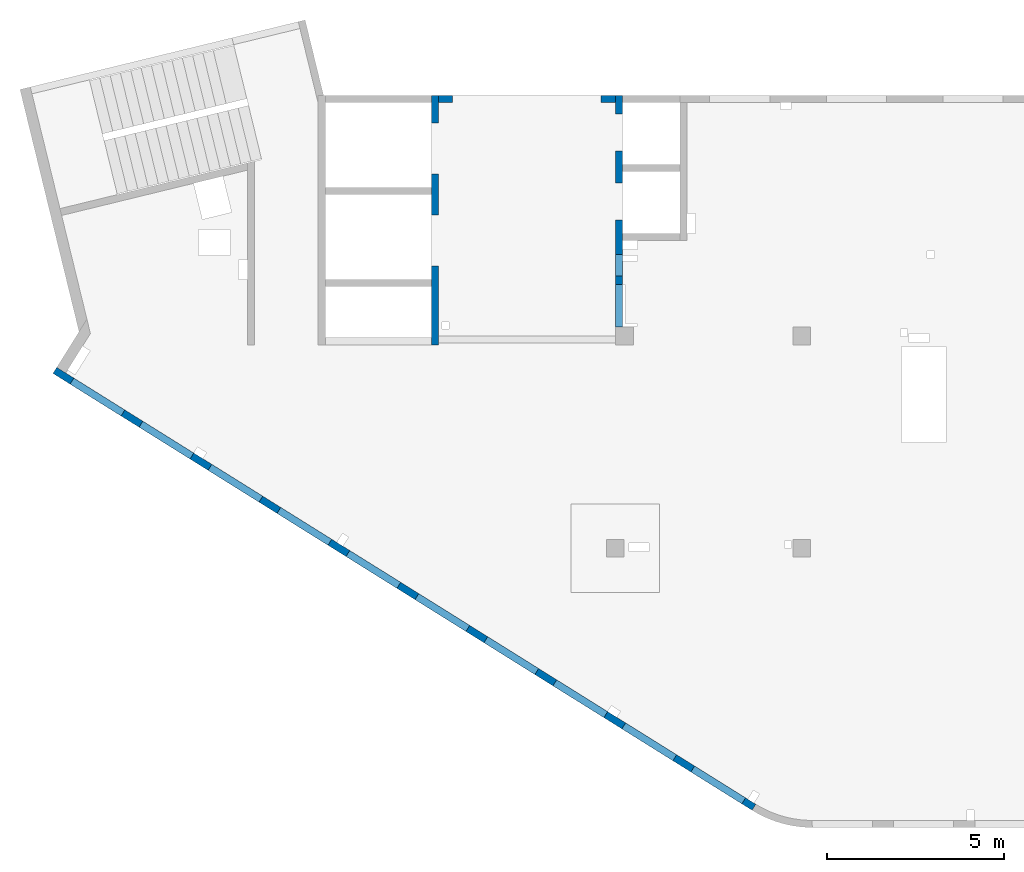
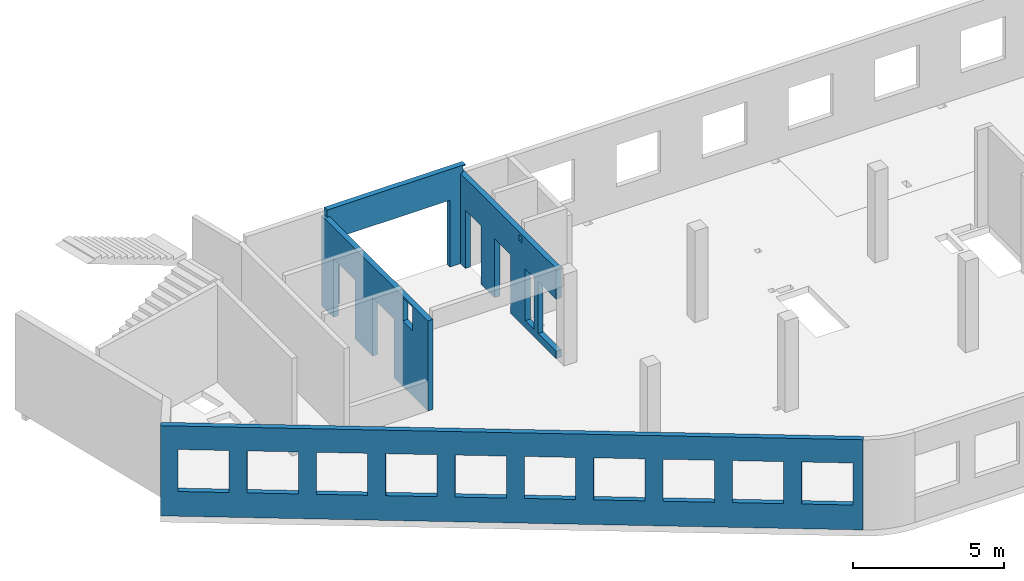
# One storey, part 4 of 6: 4 walls, 19 openings.
"""IFC4 building model written with IfcOpenShell, lengths in millimetres."""

from ifc_helpers import new_model, entity, si_unit, converted_unit, derived_unit, direction, frame, origin, place, context, subcontext, project, spatial, indexed_curve, outline, extrude, polygons, material, type_object, element, save


model = new_model("IFC4")

# Units and contexts
model_context = context("Model", 3, precision=0.01, world=origin(), true_north=direction((6.12303176911189e-17, 1.0)))
plan_context = context("Plan", 3, precision=0.01, world=origin(), true_north=direction((6.12303176911189e-17, 1.0)))
body_context = subcontext(model_context, "Body", "Model", "MODEL_VIEW")
ifc_project = project(units=[si_unit("LENGTHUNIT", "METRE", prefix="MILLI"), si_unit("AREAUNIT", "SQUARE_METRE"), si_unit("VOLUMEUNIT", "CUBIC_METRE"), converted_unit("PLANEANGLEUNIT", "DEGREE", entity("IfcRatioMeasure", 0.0174532925199433), si_unit("PLANEANGLEUNIT", "RADIAN"), dimensions=[0, 0, 0, 0, 0, 0, 0]), si_unit("MASSUNIT", "GRAM", prefix="KILO"), derived_unit("MASSDENSITYUNIT", [(si_unit("MASSUNIT", "GRAM", prefix="KILO"), 1), (si_unit("LENGTHUNIT", "METRE"), -3)]), derived_unit("MOMENTOFINERTIAUNIT", [(si_unit("LENGTHUNIT", "METRE"), 4)]), si_unit("TIMEUNIT", "SECOND"), si_unit("FREQUENCYUNIT", "HERTZ"), si_unit("THERMODYNAMICTEMPERATUREUNIT", "DEGREE_CELSIUS"), derived_unit("THERMALTRANSMITTANCEUNIT", [(si_unit("MASSUNIT", "GRAM", prefix="KILO"), 1), (si_unit("THERMODYNAMICTEMPERATUREUNIT", "KELVIN"), -1), (si_unit("TIMEUNIT", "SECOND"), -3)]), derived_unit("VOLUMETRICFLOWRATEUNIT", [(si_unit("LENGTHUNIT", "METRE"), 3), (si_unit("TIMEUNIT", "SECOND"), -1)]), derived_unit("MASSFLOWRATEUNIT", [(si_unit("MASSUNIT", "GRAM", prefix="KILO"), 1), (si_unit("TIMEUNIT", "SECOND"), -1)]), derived_unit("ROTATIONALFREQUENCYUNIT", [(si_unit("TIMEUNIT", "SECOND"), -1)]), si_unit("ELECTRICCURRENTUNIT", "AMPERE"), si_unit("ELECTRICVOLTAGEUNIT", "VOLT"), si_unit("POWERUNIT", "WATT"), si_unit("FORCEUNIT", "NEWTON", prefix="KILO"), si_unit("ILLUMINANCEUNIT", "LUX"), si_unit("LUMINOUSFLUXUNIT", "LUMEN"), si_unit("LUMINOUSINTENSITYUNIT", "CANDELA"), derived_unit("USERDEFINED", [(si_unit("MASSUNIT", "GRAM", prefix="KILO"), -1), (si_unit("LENGTHUNIT", "METRE"), -2), (si_unit("TIMEUNIT", "SECOND"), 3), (si_unit("LUMINOUSFLUXUNIT", "LUMEN"), 1)]), derived_unit("LINEARVELOCITYUNIT", [(si_unit("LENGTHUNIT", "METRE"), 1), (si_unit("TIMEUNIT", "SECOND"), -1)]), si_unit("PRESSUREUNIT", "PASCAL"), derived_unit("USERDEFINED", [(si_unit("LENGTHUNIT", "METRE"), -2), (si_unit("MASSUNIT", "GRAM", prefix="KILO"), 1), (si_unit("TIMEUNIT", "SECOND"), -2)]), derived_unit("LINEARFORCEUNIT", [(si_unit("MASSUNIT", "GRAM", prefix="KILO"), 1), (si_unit("LENGTHUNIT", "METRE"), 1), (si_unit("TIMEUNIT", "SECOND"), -2), (si_unit("LENGTHUNIT", "METRE"), -1)]), derived_unit("PLANARFORCEUNIT", [(si_unit("MASSUNIT", "GRAM", prefix="KILO"), 1), (si_unit("LENGTHUNIT", "METRE"), 1), (si_unit("TIMEUNIT", "SECOND"), -2), (si_unit("LENGTHUNIT", "METRE"), -2)])], contexts=[model_context, plan_context])

# Site, building, storey
site_placement = place(None, origin())
site = spatial("IfcSite", under=ifc_project, at=site_placement, CompositionType="ELEMENT")
building_placement = place(site_placement, origin())
building = spatial("IfcBuilding", under=site, at=building_placement, CompositionType="ELEMENT")
storey_placement = place(building_placement, frame((0.0, 0.0, 8100.0)))
storey = spatial("IfcBuildingStorey", under=building, at=storey_placement, Name="03", CompositionType="ELEMENT", Elevation=8100.0)

# Wall, openings
ifc_material = material()
wall_type = type_object("IfcWallType", Name=":ADSK_ 25_200", PredefinedType="STANDARD")
wall_1_placement = place(storey_placement, frame((19822.35, 371.16, -150.0), z_axis=(0.0, 0.0, 1.0), x_axis=(-0.848052743777574, 0.529911826412025, 0.0)))
wall_1 = element("IfcWall", 1, at=wall_1_placement, inside=storey, type_object=wall_type, material=ifc_material, Name=":ADSK_ 25_200", ObjectType=":ADSK_ 25_200", PredefinedType="NOTDEFINED", context=body_context, shape_type="Tessellation", body=[
    polygons([(341.63903172165, -99.9999999999988, 2700.0), (2041.63903172165, -99.9999999999981, 2700.0), (2041.63903172165, -99.9999999999981, 1000.00000000001), (341.63903172165, -99.9999999999988, 1000.00000000001), (2641.63903172165, -99.9999999999995, 2700.0), (4341.63903172165, -99.9999999999992, 2700.0), (4341.63903172165, -99.9999999999992, 1000.00000000001), (2641.63903172165, -99.9999999999995, 1000.00000000001), (4941.63903172166, -100.0, 2700.0), (6641.63903172166, -99.9999999999984, 2700.0), (6641.63903172166, -99.9999999999984, 1000.00000000001), (4941.63903172166, -100.0, 1000.00000000001), (7241.63903172167, -99.9999999999984, 2700.0), (8941.63903172167, -100.0, 2700.0), (8941.63903172167, -100.0, 1000.00000000001), (7241.63903172167, -99.9999999999984, 1000.00000000001), (9541.63903172167, -100.0, 2700.0), (11241.6390317217, -99.9999999999989, 2700.0), (11241.6390317217, -99.9999999999989, 1000.00000000001), (9541.63903172167, -100.0, 1000.00000000001), (11841.6390317217, -100.0, 2700.0), (13541.6390317217, -100.0, 2700.0), (13541.6390317217, -100.0, 1000.00000000001), (11841.6390317217, -100.0, 1000.00000000001), (14141.6390317217, -100.0, 2700.0), (15841.6390317217, -100.0, 2700.0), (15841.6390317217, -100.0, 1000.00000000001), (14141.6390317217, -100.0, 1000.00000000001), (16441.6390317217, -99.9999999999989, 2700.0), (18141.6390317217, -99.9999999999989, 2700.0), (18141.6390317217, -99.9999999999989, 1000.00000000001), (16441.6390317217, -99.9999999999989, 1000.00000000001), (18741.6390317217, -100.0, 2700.0), (20441.6390317217, -99.9999999999989, 2700.0), (20441.6390317217, -99.9999999999989, 1000.00000000001), (18741.6390317217, -100.0, 1000.00000000001), (21041.6390317217, -99.9999999999989, 2700.0), (22741.6390317217, -100.000000000001, 2700.0), (22741.6390317217, -100.000000000001, 1000.00000000001), (21041.6390317217, -99.9999999999989, 1000.00000000001), (-1.48894230278529e-12, -99.9999999999978, 0.0), (66.6340806380096, -99.9999999999985, 0.0), (266.636711734731, -99.9999999999993, 0.0), (4641.63671190304, -99.9999999999984, 0.0), (4941.63495785519, -100.0, 0.0), (13771.6340811649, -99.9999999999989, 0.0), (13971.6367122616, -100.000000000001, 0.0), (18441.6367124338, -100.0, 0.0), (18741.6390317217, -100.0, 0.0), (23011.6394501553, -99.9999999999989, 0.0), (23311.6394501553, -99.9999999999989, 0.0), (23311.6394501553, -99.9999999999989, 3650.0), (23011.6394501553, -99.9999999999989, 3650.0), (-1.48894230278529e-12, -99.9999999999978, 3650.0), (-2.26725305196851e-12, 100.000000000001, 0.0), (-2.26725305196851e-12, 100.000000000001, 3650.0), (23311.6394501553, 100.000000000001, 3650.0), (23311.6394501553, 99.9999999999989, 0.0), (2041.63903172165, 100.000000000323, 2700.0), (341.63903172165, 100.000000000321, 2700.0), (341.63903172165, 100.000000000321, 1000.00000000001), (2041.63903172165, 100.000000000323, 1000.00000000001), (4341.63903172165, 100.000000000322, 2700.0), (2641.63903172165, 100.00000000032, 2700.0), (2641.63903172165, 100.00000000032, 1000.00000000001), (4341.63903172165, 100.000000000322, 1000.00000000001), (6641.63903172166, 100.000000000322, 2700.0), (4941.63903172166, 100.000000000321, 2700.0), (4941.63903172166, 100.000000000321, 1000.00000000001), (6641.63903172166, 100.000000000322, 1000.00000000001), (8941.63903172166, 100.000000000321, 2700.0), (7241.63903172167, 100.000000000322, 2700.0), (7241.63903172167, 100.000000000322, 1000.00000000001), (8941.63903172166, 100.000000000321, 1000.00000000001), (11241.6390317217, 100.000000000323, 2700.0), (9541.63903172167, 100.000000000321, 2700.0), (9541.63903172167, 100.000000000321, 1000.00000000001), (11241.6390317217, 100.000000000323, 1000.00000000001), (13541.6390317217, 100.000000000319, 2700.0), (11841.6390317217, 100.000000000323, 2700.0), (11841.6390317217, 100.000000000323, 1000.00000000001), (13541.6390317217, 100.000000000319, 1000.00000000001), (15841.6390317217, 100.000000000322, 2700.0), (14141.6390317217, 100.000000000322, 2700.0), (14141.6390317217, 100.000000000322, 1000.00000000001), (15841.6390317217, 100.000000000322, 1000.00000000001), (18141.6390317217, 100.000000000322, 2700.0), (16441.6390317217, 100.000000000322, 2700.0), (16441.6390317217, 100.000000000322, 1000.00000000001), (18141.6390317217, 100.000000000322, 1000.00000000001), (20441.6390317217, 100.000000000322, 2700.0), (18741.6390317217, 100.000000000319, 2700.0), (18741.6390317217, 100.000000000319, 1000.00000000001), (20441.6390317217, 100.000000000322, 1000.00000000001), (22741.6390317217, 100.000000000319, 2700.0), (21041.6390317217, 100.000000000321, 2700.0), (21041.6390317217, 100.000000000323, 1000.00000000001), (22741.6390317217, 100.000000000319, 1000.00000000001)], [[[41, 42, 43, 44, 45, 46, 47, 48, 49, 50, 51, 52, 53, 54], [1, 2, 3, 4], [5, 6, 7, 8], [9, 10, 11, 12], [13, 14, 15, 16], [17, 18, 19, 20], [21, 22, 23, 24], [25, 26, 27, 28], [29, 30, 31, 32], [33, 34, 35, 36], [37, 38, 39, 40]], [[55, 56, 57, 58], [59, 60, 61, 62], [63, 64, 65, 66], [67, 68, 69, 70], [71, 72, 73, 74], [75, 76, 77, 78], [79, 80, 81, 82], [83, 84, 85, 86], [87, 88, 89, 90], [91, 92, 93, 94], [95, 96, 97, 98]], [[51, 50, 49, 48, 47, 46, 45, 44, 43, 42, 41, 55, 58]], [[54, 53, 52, 57, 56]], [[41, 54, 56, 55]], [[52, 51, 58, 57]], [[60, 59, 2, 1]], [[60, 1, 4, 61]], [[61, 4, 3, 62]], [[2, 59, 62, 3]], [[64, 63, 6, 5]], [[64, 5, 8, 65]], [[65, 8, 7, 66]], [[6, 63, 66, 7]], [[68, 67, 10, 9]], [[68, 9, 12, 69]], [[69, 12, 11, 70]], [[10, 67, 70, 11]], [[72, 71, 14, 13]], [[72, 13, 16, 73]], [[73, 16, 15, 74]], [[14, 71, 74, 15]], [[76, 75, 18, 17]], [[76, 17, 20, 77]], [[77, 20, 19, 78]], [[18, 75, 78, 19]], [[80, 79, 22, 21]], [[80, 21, 24, 81]], [[81, 24, 23, 82]], [[22, 79, 82, 23]], [[84, 83, 26, 25]], [[84, 25, 28, 85]], [[85, 28, 27, 86]], [[26, 83, 86, 27]], [[88, 87, 30, 29]], [[88, 29, 32, 89]], [[89, 32, 31, 90]], [[30, 87, 90, 31]], [[92, 91, 34, 33]], [[92, 33, 36, 93]], [[93, 36, 35, 94]], [[34, 91, 94, 35]], [[96, 95, 38, 37]], [[96, 37, 40, 97]], [[97, 40, 39, 98]], [[38, 95, 98, 39]]], closed=True),
])
placement_1 = place(wall_1_placement, frame((16613.72, 10818.86, 150.0), z_axis=(0.0, 0.0, 1.0), x_axis=(-0.848052743777574, -0.529911826412026, 0.0)))
element("IfcOpeningElement", 2, at=placement_1, cuts=wall_1, Name=":ADSK_ 25_200", PredefinedType="OPENING", context=body_context, shape_type="SweptSolid", body=[
    extrude(outline(indexed_curve([(-849.999999999993, -850.0), (849.999999999994, -850.0), (849.999999999994, 850.0), (-849.999999999993, 850.0), (-849.999999999993, -850.0)], self_intersect=False)), frame((1310.08, 12056.6, 1700.0), z_axis=(-0.529911826412026, -0.848052743777574, 0.0), x_axis=(0.0, 0.0, -1.0)), (0.0, 0.0, 1.0), 200.000000000964),
])
element("IfcOpeningElement", 3, at=placement_1, cuts=wall_1, Name=":ADSK_ 25_200", PredefinedType="OPENING", context=body_context, shape_type="SweptSolid", body=[
    extrude(outline(indexed_curve([(-849.999999999993, -850.0), (849.999999999994, -850.0), (849.999999999994, 850.0), (-849.999999999993, 850.0), (-849.999999999993, -850.0)], self_intersect=False)), frame((3260.6, 10837.81, 1700.0), z_axis=(-0.529911826412026, -0.848052743777574, 0.0), x_axis=(0.0, 0.0, -1.0)), (0.0, 0.0, 1.0), 200.000000000964),
])
element("IfcOpeningElement", 4, at=placement_1, cuts=wall_1, Name=":ADSK_ 25_200", PredefinedType="OPENING", context=body_context, shape_type="SweptSolid", body=[
    extrude(outline(indexed_curve([(-849.999999999993, -850.0), (849.999999999994, -850.0), (849.999999999994, 850.0), (-849.999999999993, 850.0), (-849.999999999993, -850.0)], self_intersect=False)), frame((5211.12, 9619.01, 1700.0), z_axis=(-0.529911826412025, -0.848052743777574, 0.0), x_axis=(0.0, 0.0, -1.0)), (0.0, 0.0, 1.0), 200.000000000962),
])
element("IfcOpeningElement", 5, at=placement_1, cuts=wall_1, Name=":ADSK_ 25_200", PredefinedType="OPENING", context=body_context, shape_type="SweptSolid", body=[
    extrude(outline(indexed_curve([(-849.999999999993, -849.999999999999), (849.999999999994, -849.999999999999), (849.999999999994, 850.0), (-849.999999999993, 850.0), (-849.999999999993, -849.999999999999)], self_intersect=False)), frame((7161.64, 8400.21, 1700.0), z_axis=(-0.529911826412026, -0.848052743777574, 0.0), x_axis=(0.0, 0.0, -1.0)), (0.0, 0.0, 1.0), 200.000000000962),
])
element("IfcOpeningElement", 6, at=placement_1, cuts=wall_1, Name=":ADSK_ 25_200", PredefinedType="OPENING", context=body_context, shape_type="SweptSolid", body=[
    extrude(outline(indexed_curve([(-849.999999999993, -849.999999999999), (849.999999999994, -849.999999999999), (849.999999999994, 850.0), (-849.999999999993, 850.0), (-849.999999999993, -849.999999999999)], self_intersect=False)), frame((9112.16, 7181.41, 1700.0), z_axis=(-0.529911826412026, -0.848052743777574, 0.0), x_axis=(0.0, 0.0, -1.0)), (0.0, 0.0, 1.0), 200.000000000962),
])
element("IfcOpeningElement", 7, at=placement_1, cuts=wall_1, Name=":ADSK_ 25_200", PredefinedType="OPENING", context=body_context, shape_type="SweptSolid", body=[
    extrude(outline(indexed_curve([(-849.999999999993, -850.0), (849.999999999994, -850.0), (849.999999999994, 850.0), (-849.999999999993, 850.0), (-849.999999999993, -850.0)], self_intersect=False)), frame((11062.68, 5962.62, 1700.0), z_axis=(-0.529911826412025, -0.848052743777574, 0.0), x_axis=(0.0, 0.0, -1.0)), (0.0, 0.0, 1.0), 200.000000000964),
])
element("IfcOpeningElement", 8, at=placement_1, cuts=wall_1, Name=":ADSK_ 25_200", PredefinedType="OPENING", context=body_context, shape_type="SweptSolid", body=[
    extrude(outline(indexed_curve([(-849.999999999993, -850.0), (849.999999999994, -850.0), (849.999999999994, 850.0), (-849.999999999993, 850.0), (-849.999999999993, -850.0)], self_intersect=False)), frame((13013.21, 4743.82, 1700.0), z_axis=(-0.529911826412025, -0.848052743777574, 0.0), x_axis=(0.0, 0.0, -1.0)), (0.0, 0.0, 1.0), 200.000000000959),
])
element("IfcOpeningElement", 9, at=placement_1, cuts=wall_1, Name=":ADSK_ 25_200", PredefinedType="OPENING", context=body_context, shape_type="SweptSolid", body=[
    extrude(outline(indexed_curve([(-849.999999999993, -850.000000000002), (849.999999999994, -850.000000000002), (849.999999999994, 849.999999999998), (-849.999999999993, 849.999999999998), (-849.999999999993, -850.000000000002)], self_intersect=False)), frame((14963.73, 3525.02, 1700.0), z_axis=(-0.529911826412025, -0.848052743777574, 0.0), x_axis=(0.0, 0.0, -1.0)), (0.0, 0.0, 1.0), 200.000000000962),
])
element("IfcOpeningElement", 10, at=placement_1, cuts=wall_1, Name=":ADSK_ 25_200", PredefinedType="OPENING", context=body_context, shape_type="SweptSolid", body=[
    extrude(outline(indexed_curve([(-849.999999999993, -850.0), (849.999999999994, -850.0), (849.999999999994, 850.0), (-849.999999999993, 850.0), (-849.999999999993, -850.0)], self_intersect=False)), frame((16914.25, 2306.23, 1700.0), z_axis=(-0.529911826412025, -0.848052743777574, 0.0), x_axis=(0.0, 0.0, -1.0)), (0.0, 0.0, 1.0), 200.000000000962),
])
element("IfcOpeningElement", 11, at=placement_1, cuts=wall_1, Name=":ADSK_ 25_200", PredefinedType="OPENING", context=body_context, shape_type="SweptSolid", body=[
    extrude(outline(indexed_curve([(-849.999999999993, -850.0), (849.999999999994, -850.0), (849.999999999994, 850.0), (-849.999999999993, 850.0), (-849.999999999993, -850.0)], self_intersect=False)), frame((18864.77, 1087.43, 1700.0), z_axis=(-0.529911826412025, -0.848052743777574, 0.0), x_axis=(0.0, 0.0, -1.0)), (0.0, 0.0, 1.0), 200.000000000966),
])

wall_2_placement = place(storey_placement, frame((16000.0, 20500.0, -150.0), z_axis=(0.0, 0.0, 1.0), x_axis=(0.0, -1.0, 0.0)))
wall_2 = element("IfcWall", 12, at=wall_2_placement, inside=storey, type_object=wall_type, material=ifc_material, Name=":ADSK_ 25_200", ObjectType=":ADSK_ 25_200", PredefinedType="NOTDEFINED", context=body_context, shape_type="Tessellation", body=[
    polygons([(4100.00063936683, -100.000000000321, 3550.0), (4300.00063936683, -100.00000000032, 3550.0), (4300.00063936683, -100.00000000032, 3300.00000000001), (4100.00063936683, -100.000000000321, 3300.00000000001), (4500.00063936683, -99.9999999999995, 2399.99999999999), (5100.00063936683, -100.000000000001, 2399.99999999999), (5100.00063936683, -100.000000000001, 300.000000000001), (4500.00063936683, -99.9999999999995, 300.000000000001), (6550.00048980714, -99.9999999999982, 3650.0), (400.000000000009, -99.9999999999998, 3650.0), (200.000000000002, -100.0, 3650.0), (0.0, -100.0, 3650.0), (0.0, -100.0, 0.0), (200.000000000002, -100.0, 0.0), (529.999999999996, -99.9999999999995, 0.0), (529.999999999996, -99.9999999999995, 2369.99999999805), (1570.0, -100.000000000002, 2369.99999999805), (1570.0, -100.000000000002, 0.0), (2480.0, -100.000000000001, 0.0), (2480.0, -100.000000000001, 2369.99999999805), (3519.99999999999, -100.000000000001, 2369.99999999805), (3519.99999999999, -100.000000000001, 0.0), (6550.00048980714, -99.9999999999982, 0.0), (6550.00048980714, -99.9999999999982, 300.000000000001), (5350.00048980714, -100.0, 300.000000000001), (5350.00048980714, -100.0, 2399.99999999999), (6550.00048980714, -99.9999999999982, 2399.99999999999), (4300.00063936683, 100.0, 3550.0), (4100.00063936683, 99.9999999999999, 3550.0), (4100.00063936683, 99.9999999999999, 3300.00000000001), (4300.00063936683, 100.0, 3300.00000000001), (5100.00063936683, 99.9999999999994, 2399.99999999999), (4500.00063936683, 99.9999999999984, 2399.99999999998), (4500.00063936683, 99.9999999999984, 300.000000000001), (5100.00063936683, 99.9999999999994, 300.000000000001), (0.0, 99.9999999999996, 3650.0), (200.000000000002, 99.9999999999999, 3650.0), (3900.00063936685, 99.9999999999995, 3650.0), (4100.00063936685, 99.9999999999999, 3650.0), (4300.00063936685, 100.0, 3650.0), (4525.00063936685, 100.000000000001, 3650.0), (4685.00063936685, 99.9999999999987, 3650.0), (5340.00063936685, 99.9999999999998, 3650.0), (6530.00063936685, 99.9999999999996, 3650.0), (6550.00048980714, 99.9999999999996, 3650.0), (6550.00048980714, 99.9999999999996, 2399.99999999999), (5350.00048980714, 99.9999999999998, 2399.99999999998), (5350.00048980714, 99.9999999999998, 300.000000000001), (6550.00048980714, 99.9999999999996, 300.000000000001), (6550.00048980714, 99.9999999999996, 0.0), (4100.00063936683, 99.9999999999999, 0.0), (3900.00063936683, 99.9999999999995, 0.0), (3519.99999999999, 99.9999999999989, 0.0), (3519.99999999999, 99.9999999999989, 2369.99999999805), (2480.0, 100.000000000002, 2369.99999999804), (2480.0, 100.000000000002, 0.0), (1570.0, 100.0, 0.0), (1570.0, 100.0, 2369.99999999805), (529.999999999996, 100.0, 2369.99999999804), (529.999999999996, 100.0, 0.0), (0.0, 99.9999999999996, 0.0), (0.0, 6.56688670961758e-13, 3650.0)], [[[9, 10, 11, 12, 13, 14, 15, 16, 17, 18, 19, 20, 21, 22, 23, 24, 25, 26, 27], [1, 2, 3, 4], [5, 6, 7, 8]], [[36, 37, 38, 39, 40, 41, 42, 43, 44, 45, 46, 47, 48, 49, 50, 51, 52, 53, 54, 55, 56, 57, 58, 59, 60, 61], [28, 29, 30, 31], [32, 33, 34, 35]], [[13, 61, 60, 15, 14]], [[23, 50, 49, 24]], [[12, 11, 10, 9, 45, 44, 43, 42, 41, 40, 39, 38, 37, 36, 62]], [[13, 12, 62, 36, 61]], [[2, 1, 29, 28]], [[2, 28, 31, 3]], [[3, 31, 30, 4]], [[29, 1, 4, 30]], [[32, 6, 5, 33]], [[33, 5, 8, 34]], [[34, 8, 7, 35]], [[6, 32, 35, 7]], [[26, 47, 46, 27]], [[47, 26, 25, 48]], [[48, 25, 24, 49]], [[54, 21, 20, 55]], [[55, 20, 19, 56]], [[21, 54, 53, 22]], [[58, 17, 16, 59]], [[59, 16, 15, 60]], [[17, 58, 57, 18]], [[45, 9, 27, 46]], [[56, 19, 18, 57]], [[50, 23, 22, 53, 52, 51]]], closed=True),
])
placement_2 = place(wall_2_placement, frame((20500.0, -16000.0, 150.0), z_axis=(0.0, 0.0, 1.0), x_axis=(0.0, 1.0, 0.0)))
element("IfcOpeningElement", 13, at=placement_2, cuts=wall_2, Name=":ADSK_ 25_200", PredefinedType="OPENING", context=body_context, shape_type="SweptSolid", body=[
    extrude(outline(indexed_curve([(-1049.99999999999, -600.0), (1049.99999999999, -600.0), (1049.99999999999, 600.0), (-1049.99999999999, 600.0), (-1049.99999999999, -600.0)], self_intersect=False)), frame((15800.0, 14550.0, 1200.0), z_axis=(1.0, 0.0, 0.0), x_axis=(0.0, 0.0, -1.0)), (0.0, 0.0, 1.0), 400.000000001943),
])
element("IfcOpeningElement", 14, at=placement_2, cuts=wall_2, Name=":ADSK_ 25_200", PredefinedType="OPENING", context=body_context, shape_type="SweptSolid", body=[
    extrude(outline(indexed_curve([(-1184.99999999902, -520.000000000001), (1184.99999999902, -520.000000000001), (1184.99999999902, 519.999999999999), (-1184.99999999902, 519.999999999999), (-1184.99999999902, -520.000000000001)], self_intersect=False)), frame((15800.0, 17500.0, 1035.0), z_axis=(1.0, 0.0, 0.0), x_axis=(0.0, 0.0, -1.0)), (0.0, 0.0, 1.0), 400.000000001943),
])
element("IfcOpeningElement", 15, at=placement_2, cuts=wall_2, Name=":ADSK_ 25_200", PredefinedType="OPENING", context=body_context, shape_type="SweptSolid", body=[
    extrude(outline(indexed_curve([(-1184.99999999902, -519.999999999999), (1184.99999999902, -519.999999999999), (1184.99999999902, 520.000000000001), (-1184.99999999902, 520.000000000001), (-1184.99999999902, -519.999999999999)], self_intersect=False)), frame((15800.0, 19450.0, 1035.0), z_axis=(1.0, 0.0, 0.0), x_axis=(0.0, 0.0, -1.0)), (0.0, 0.0, 1.0), 400.000000001943),
])
element("IfcOpeningElement", 16, at=placement_2, cuts=wall_2, Name=":ADSK_ 25_200", PredefinedType="OPENING", context=body_context, shape_type="SweptSolid", body=[
    extrude(outline(indexed_curve([(-100.000000000001, -124.999999999993), (99.9999999999989, -124.999999999993), (99.9999999999989, 124.999999999993), (-100.000000000001, 124.999999999993), (-100.000000000001, -124.999999999993)], self_intersect=False)), frame((15900.0, 16300.0, 3275.0), z_axis=(1.0, 0.0, 0.0), x_axis=(0.0, -1.0, 0.0)), (0.0, 0.0, 1.0), 200.000000000962),
])
element("IfcOpeningElement", 17, at=placement_2, cuts=wall_2, Name=":ADSK_ 25_200", PredefinedType="OPENING", context=body_context, shape_type="SweptSolid", body=[
    extrude(outline(indexed_curve([(-1049.99999999999, -300.000000000001), (1049.99999999999, -300.000000000001), (1049.99999999999, 299.999999999999), (-1049.99999999999, 299.999999999999), (-1049.99999999999, -300.000000000001)], self_intersect=False)), frame((15800.0, 15700.0, 1200.0), z_axis=(1.0, 0.0, 0.0), x_axis=(0.0, 0.0, -1.0)), (0.0, 0.0, 1.0), 400.000000001943),
])

wall_3_placement = place(storey_placement, frame((10800.0, 20500.0, -150.0), z_axis=(0.0, 0.0, 1.0), x_axis=(0.0, -1.0, 0.0)))
wall_3 = element("IfcWall", 18, at=wall_3_placement, inside=storey, type_object=wall_type, material=ifc_material, Name=":ADSK_ 25_200", ObjectType=":ADSK_ 25_200", PredefinedType="NOTDEFINED", context=body_context, shape_type="Tessellation", body=[
    polygons([(5400.00000000002, -99.999999999999, 3600.0), (6050.00000000002, -99.9999999999979, 3600.0), (6050.00000000002, -99.9999999999979, 2650.00000000001), (5400.00000000002, -99.999999999999, 2650.00000000001), (7050.00063936683, -99.9999999999985, 3650.0), (6850.00063936682, -99.9999999999988, 3650.0), (200.000000000028, -99.9999999999985, 3650.0), (0.0, -99.9999999999988, 3650.0), (0.0, -99.9999999999988, 0.0), (780.000000000018, -99.9999999999976, 0.0), (780.000000000018, -99.9999999999976, 2369.99999999805), (2220.00000000001, -99.9999999999975, 2369.99999999804), (2220.00000000001, -99.9999999999997, 0.0), (3380.00000000002, -99.9999999999978, 0.0), (3380.00000000002, -99.9999999999978, 2369.99999999805), (4820.00000000001, -99.9999999999977, 2369.99999999805), (4820.00000000001, -99.9999999999977, 0.0), (6850.00063936683, -99.9999999999988, 0.0), (7050.00063936683, -99.9999999999985, 0.0), (7050.00063936683, -99.9999999999985, 1200.0), (0.0, 100.000000000001, 3650.0), (200.000000000002, 100.000000000001, 3650.0), (400.00000000003, 100.000000000002, 3650.0), (6400.00063936682, 100.0, 3650.0), (6600.00063936682, 100.000000000001, 3650.0), (7050.00063936683, 100.000000000001, 3650.0), (7050.00063936683, 100.000000000001, 0.0), (4820.00000000001, 100.000000000002, 0.0), (4820.00000000002, 100.000000000002, 2369.99999999805), (3380.00000000002, 100.000000000002, 2369.99999999804), (3380.00000000002, 100.000000000002, 0.0), (2220.00000000001, 100.000000000003, 0.0), (2220.00000000001, 100.000000000003, 2369.99999999805), (780.000000000018, 100.000000000002, 2369.99999999805), (780.000000000018, 100.000000000002, 0.0), (200.000000000002, 100.000000000001, 0.0), (0.0, 100.000000000001, 0.0), (6050.00000000002, 100.000000000323, 3600.0), (5400.00000000002, 100.000000000322, 3600.0), (5400.00000000002, 100.000000000322, 2650.00000000001), (6050.00000000002, 100.000000000323, 2650.00000000001), (0.0, 7.90446333772861e-14, 3650.0)], [[[5, 6, 7, 8, 9, 10, 11, 12, 13, 14, 15, 16, 17, 18, 19, 20], [1, 2, 3, 4]], [[21, 22, 23, 24, 25, 26, 27, 28, 29, 30, 31, 32, 33, 34, 35, 36, 37], [38, 39, 40, 41]], [[9, 37, 36, 35, 10]], [[8, 7, 6, 5, 26, 25, 24, 23, 22, 21, 42]], [[9, 8, 42, 21, 37]], [[39, 38, 2, 1]], [[39, 1, 4, 40]], [[40, 4, 3, 41]], [[2, 38, 41, 3]], [[11, 34, 33, 12]], [[12, 33, 32, 13]], [[34, 11, 10, 35]], [[29, 16, 15, 30]], [[30, 15, 14, 31]], [[16, 29, 28, 17]], [[5, 20, 19, 27, 26]], [[13, 32, 31, 14]], [[27, 19, 18, 17, 28]]], closed=True),
])
placement_3 = place(wall_3_placement, frame((20500.0, -10800.0, 150.0), z_axis=(0.0, 0.0, 1.0), x_axis=(0.0, 1.0, 0.0)))
element("IfcOpeningElement", 19, at=placement_3, cuts=wall_3, Name=":ADSK_ 25_200", PredefinedType="OPENING", context=body_context, shape_type="SweptSolid", body=[
    extrude(outline(indexed_curve([(-719.999999999999, -1184.99999999902), (719.999999999999, -1184.99999999902), (719.999999999999, 1184.99999999902), (-719.999999999999, 1184.99999999902), (-719.999999999999, -1184.99999999902)], self_intersect=False)), frame((10600.0, 19000.0, 1035.0), z_axis=(1.0, 0.0, 0.0), x_axis=(0.0, -1.0, 0.0)), (0.0, 0.0, 1.0), 400.000000001943),
])
element("IfcOpeningElement", 20, at=placement_3, cuts=wall_3, Name=":ADSK_ 25_200", PredefinedType="OPENING", context=body_context, shape_type="SweptSolid", body=[
    extrude(outline(indexed_curve([(-1184.99999999902, -719.999999999999), (1184.99999999902, -719.999999999999), (1184.99999999902, 720.000000000001), (-1184.99999999902, 720.000000000001), (-1184.99999999902, -719.999999999999)], self_intersect=False)), frame((10600.0, 16400.0, 1035.0), z_axis=(1.0, 0.0, 0.0), x_axis=(0.0, 0.0, -1.0)), (0.0, 0.0, 1.0), 400.000000001943),
])
element("IfcOpeningElement", 21, at=placement_3, cuts=wall_3, Name=":ADSK_ 25_200", PredefinedType="OPENING", context=body_context, shape_type="SweptSolid", body=[
    extrude(outline(indexed_curve([(-474.999999999994, -325.0), (474.999999999992, -325.0), (474.999999999992, 325.0), (-474.999999999994, 325.0), (-474.999999999994, -325.0)], self_intersect=False)), frame((10700.0, 14775.0, 2975.0), z_axis=(1.0, 0.0, 0.0), x_axis=(0.0, 0.0, -1.0)), (0.0, 0.0, 1.0), 200.000000000962),
])

# Wall, opening
wall_4_placement = place(storey_placement, frame((10800.0, 20400.0, -150.0)))
wall_4 = element("IfcWall", 22, at=wall_4_placement, inside=storey, type_object=wall_type, material=ifc_material, Name=":ADSK_ 25_200", ObjectType=":ADSK_ 25_200", PredefinedType="NOTDEFINED", context=body_context, shape_type="Tessellation", body=[
    polygons([(5300.00000000001, -100.000000000003, 3950.0), (5100.00000000001, -100.000000000003, 3950.0), (100.000000000001, -100.000000000003, 3950.0), (-4.99784381508401e-13, -100.000000000003, 3950.0), (-4.99784381508401e-13, -100.000000000003, 3900.0), (-4.99784381508401e-13, -100.000000000003, 3650.0), (100.000000000001, -100.000000000003, 3650.0), (100.000000000001, -100.000000000003, 0.0), (499.999999999992, -99.9999999999989, 0.0), (499.999999999994, -100.000000000003, 2699.99999999804), (4699.99999999999, -100.000000000003, 2699.99999999804), (4699.99999999999, -100.000000000003, 0.0), (5100.00000000001, -100.000000000003, 0.0), (5100.00000000001, -100.000000000003, 3650.0), (5200.00000000001, -100.000000000003, 3650.0), (5200.00000000001, -100.000000000003, 3900.0), (5300.00000000001, -100.000000000003, 3900.0), (-1.16616415338434e-12, 99.9999999999989, 3950.0), (99.9999999999999, 99.9999999999989, 3950.0), (5100.00000000001, 99.9999999999989, 3950.0), (5300.0, 99.9999999999989, 3950.0), (5300.0, 99.9999999999989, 3900.0), (5200.00000000001, 99.9999999999989, 3900.0), (5200.00000000001, 99.9999999999989, 3650.0), (5100.0, 99.9999999999989, 3650.0), (5100.0, 99.9999999999989, 0.0), (4699.99999999999, 99.9999999999989, 0.0), (4699.99999999999, 99.9999999999989, 2699.99999999804), (499.999999999993, 100.000000000003, 2699.99999999804), (499.999999999993, 100.000000000003, 0.0), (99.9999999999999, 99.9999999999989, 0.0), (99.9999999999999, 99.9999999999989, 3650.0), (-1.16616415338434e-12, 99.9999999999989, 3650.0), (-1.16616415338434e-12, 99.9999999999989, 3900.0)], [[[1, 2, 3, 4, 5, 6, 7, 8, 9, 10, 11, 12, 13, 14, 15, 16, 17]], [[18, 19, 20, 21, 22, 23, 24, 25, 26, 27, 28, 29, 30, 31, 32, 33, 34]], [[8, 31, 30, 9]], [[4, 3, 2, 1, 21, 20, 19, 18]], [[10, 29, 28, 11]], [[11, 28, 27, 12]], [[29, 10, 9, 30]], [[24, 15, 14, 25]], [[15, 24, 23, 16]], [[17, 16, 23, 22]], [[13, 26, 25, 14]], [[21, 1, 17, 22]], [[6, 33, 32, 7]], [[4, 18, 34, 33, 6, 5]], [[31, 8, 7, 32]], [[26, 13, 12, 27]]], closed=True),
])
opening_19_placement = place(wall_4_placement, frame((-10800.0, -20400.0, 150.0)))
element("IfcOpeningElement", 23, at=opening_19_placement, cuts=wall_4, Name=":ADSK_ 25_200", PredefinedType="OPENING", context=body_context, shape_type="SweptSolid", body=[
    extrude(outline(indexed_curve([(-2100.0, -1349.99999999902), (2100.0, -1349.99999999902), (2100.0, 1349.99999999902), (-2100.0, 1349.99999999902), (-2100.0, -1349.99999999902)], self_intersect=False)), frame((13400.0, 20200.0, 1200.0), z_axis=(0.0, 1.0, 0.0), x_axis=(1.0, 0.0, 0.0)), (0.0, 0.0, 1.0), 400.000000001945),
])

save(model, "model.ifc")
